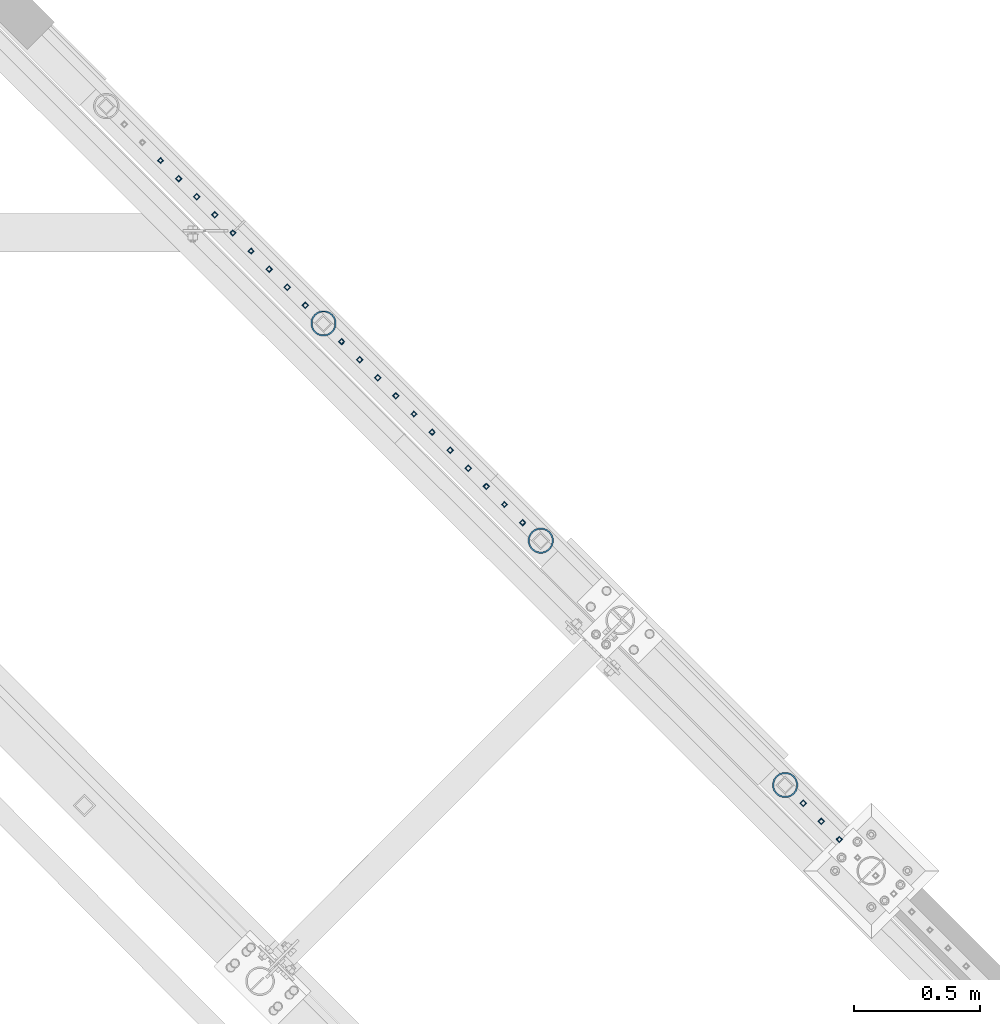
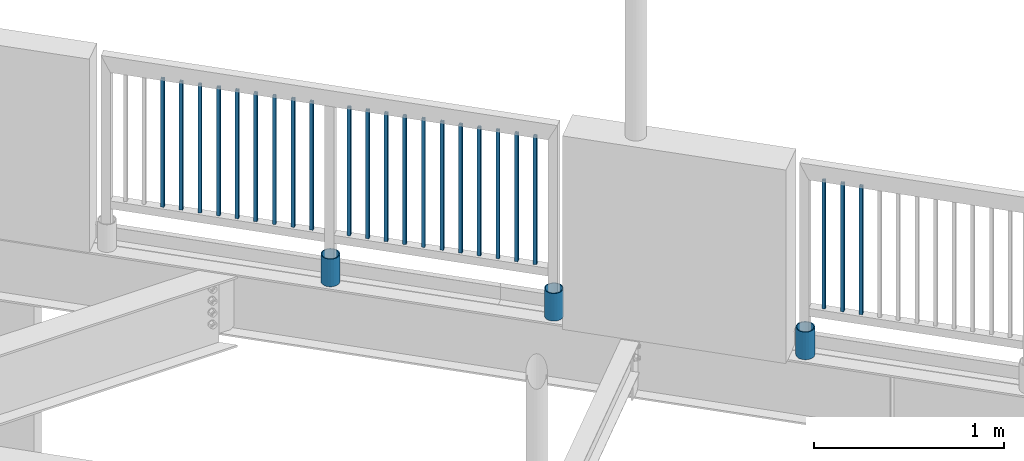
# One storey, part 284 of 975: 26 columns.
"""IFC2X3 building model written with IfcOpenShell, lengths in millimetres."""

from ifc_helpers import new_model, si_unit, frame, origin_with_axes, place, context, subcontext, project, spatial, faceted_brep, material, type_object, element, save


model = new_model("IFC2X3")

# Units and contexts
model_context = context("Model", 3, precision=1e-05, world=origin_with_axes())
body_context = subcontext(model_context, "Body", "Model", "MODEL_VIEW")
ifc_project = project(units=[si_unit("LENGTHUNIT", "METRE", prefix="MILLI"), si_unit("AREAUNIT", "SQUARE_METRE"), si_unit("VOLUMEUNIT", "CUBIC_METRE"), si_unit("MASSUNIT", "GRAM", prefix="KILO"), si_unit("TIMEUNIT", "SECOND"), si_unit("PLANEANGLEUNIT", "RADIAN"), si_unit("SOLIDANGLEUNIT", "STERADIAN"), si_unit("THERMODYNAMICTEMPERATUREUNIT", "DEGREE_CELSIUS"), si_unit("LUMINOUSINTENSITYUNIT", "LUMEN")], contexts=[model_context])

# Site, building, storey
site_placement = place(None, origin_with_axes())
site = spatial("IfcSite", under=ifc_project, at=site_placement, CompositionType="ELEMENT")
building_placement = place(site_placement, origin_with_axes())
building = spatial("IfcBuilding", under=site, at=building_placement, Name="Undefined", CompositionType="ELEMENT")
storey_placement = place(building_placement, origin_with_axes())
storey = spatial("IfcBuildingStorey", under=building, at=storey_placement, Name="Undefined", CompositionType="ELEMENT", Elevation=0.0)

# Columns
ifc_material_1 = material()
column_type_1 = type_object("IfcColumnType", Name="HSS3/4X3/4X.120_TUBES", PredefinedType="NOTDEFINED")
for number, where, z_axis, x_axis, name in (
    (1, (27726.1994759871, 20908.4255492216, 4254.49914984075), (-0.707106781186601, 0.707106781186494, 2.36468622460961e-14), (0.0, 0.0, 1.0), "PICKET"),
    (2, (27798.0338509871, 20836.5911742216, 4254.49914984075), (-0.707106781186601, 0.707106781186494, 2.36468622460961e-14), (0.0, 0.0, 1.0), "PICKET"),
    (3, (27869.8682259871, 20764.7567992216, 4254.49914984075), (-0.707106781186601, 0.707106781186494, 2.36468622460961e-14), (0.0, 0.0, 1.0), "PICKET"),
    (4, (27941.7026009871, 20692.9224242216, 4254.49914984075), (-0.707106781186601, 0.707106781186494, 2.36468622460961e-14), (0.0, 0.0, 1.0), "PICKET"),
    (5, (28013.5369759871, 20621.0880492216, 4254.49914984075), (-0.707106781186601, 0.707106781186494, 2.36468622460961e-14), (0.0, 0.0, 1.0), "PICKET"),
    (6, (28085.3713509871, 20549.2536742216, 4254.49914984075), (-0.707106781186601, 0.707106781186494, 2.36468622460961e-14), (0.0, 0.0, 1.0), "PICKET"),
    (7, (28157.2057259871, 20477.4192992216, 4254.49914984075), (-0.707106781186601, 0.707106781186494, 2.36468622460961e-14), (0.0, 0.0, 1.0), "PICKET"),
    (8, (28229.0401009871, 20405.5849242216, 4254.49914984075), (-0.707106781186601, 0.707106781186494, 2.36468622460961e-14), (0.0, 0.0, 1.0), "PICKET"),
    (9, (28300.8744759871, 20333.7505492216, 4254.49914984075), (-0.707106781186601, 0.707106781186494, 2.36468622460961e-14), (0.0, 0.0, 1.0), "PICKET"),
    (10, (28444.5970604277, 20189.9439310617, 4254.49994796676), (-0.707106781186601, 0.707106781186494, 2.36468622460961e-14), (0.0, 0.0, 1.0), "PICKET"),
    (11, (28516.4314354277, 20118.1095560617, 4254.49994796676), (-0.707106781186601, 0.707106781186494, 2.36468622460961e-14), (0.0, 0.0, 1.0), "PICKET"),
    (12, (28588.2658104277, 20046.2751810617, 4254.49994796676), (-0.707106781186601, 0.707106781186494, 2.36468622460961e-14), (0.0, 0.0, 1.0), "PICKET"),
    (13, (28660.1001854277, 19974.4408060617, 4254.49994796676), (-0.707106781186601, 0.707106781186494, 2.36468622460961e-14), (0.0, 0.0, 1.0), "PICKET"),
    (14, (28731.9345604277, 19902.6064310617, 4254.49994796676), (-0.707106781186601, 0.707106781186494, 2.36468622460961e-14), (0.0, 0.0, 1.0), "PICKET"),
    (15, (28803.7689354277, 19830.7720560617, 4254.49994796676), (-0.707106781186601, 0.707106781186494, 2.36468622460961e-14), (0.0, 0.0, 1.0), "PICKET"),
    (16, (28875.6033104277, 19758.9376810617, 4254.49994796676), (-0.707106781186601, 0.707106781186494, 2.36468622460961e-14), (0.0, 0.0, 1.0), "PICKET"),
    (17, (28947.4376854277, 19687.1033060617, 4254.49994796676), (-0.707106781186601, 0.707106781186494, 2.36468622460961e-14), (0.0, 0.0, 1.0), "PICKET"),
    (18, (29019.2720604277, 19615.2689310617, 4254.49994796676), (-0.707106781186601, 0.707106781186494, 2.36468622460961e-14), (0.0, 0.0, 1.0), "PICKET"),
    (19, (29091.1064354277, 19543.4345560617, 4254.49994796676), (-0.707106781186601, 0.707106781186494, 2.36468622460961e-14), (0.0, 0.0, 1.0), "PICKET"),
    (20, (29162.9408104277, 19471.6001810617, 4254.49994796676), (-0.707106781186601, 0.707106781186494, 2.36468622460961e-14), (0.0, 0.0, 1.0), "PICKET"),
    (21, (30276.5088978262, 18357.923543701, 4254.499875366), (-0.707106781186601, 0.707106781186494, 2.36468622460961e-14), (0.0, 0.0, 1.0), "PICKET"),
    (22, (30348.3432728262, 18286.089168701, 4254.499875366), (-0.707106781186601, 0.707106781186494, 2.36468622460961e-14), (0.0, 0.0, 1.0), "PICKET"),
    (23, (30420.1776478262, 18214.254793701, 4254.499875366), (-0.707106781186601, 0.707106781186494, 2.36468622460961e-14), (0.0, 0.0, 1.0), "PICKET"),
):
    element("IfcColumn", number, at=place(storey_placement, frame(where, z_axis=z_axis, x_axis=x_axis)), inside=storey, type_object=column_type_1, material=ifc_material_1, Name=name, ObjectType="HSS3/4X3/4X.120_TUBES", context=body_context, shape_type="Brep", body=[
        faceted_brep([(0.0, 6.34999999998763, -6.34999999998763), (0.0, -6.35000000000582, -6.34999999998763), (825.49997943247, -6.35000000000582, -6.34999999998763), (825.49997943247, 6.34999999998763, -6.34999999998763), (0.0, -6.34999999998763, 6.34999999998763), (825.49997943247, -6.34999999998763, 6.34999999998763), (0.0, 6.35000000000946, 6.34999999998763), (825.49997943247, 6.35000000000946, 6.34999999998763), (0.0, 9.52499999997963, -9.52499999997963), (0.0, 9.52500000000873, 9.5249999999869), (825.49997943247, 9.52500000000873, 9.5249999999869), (825.49997943247, 9.52499999997963, -9.52499999997963), (0.0, -9.52499999997963, 9.52499999998327), (825.49997943247, -9.52499999997963, 9.52499999998327), (0.0, -9.52500000000873, -9.5249999999869), (825.49997943247, -9.52500000000873, -9.5249999999869)], [[[0, 1, 2, 3]], [[1, 4, 5, 2]], [[4, 6, 7, 5]], [[6, 0, 3, 7]], [[8, 9, 10, 11]], [[9, 12, 13, 10]], [[12, 14, 15, 13]], [[14, 8, 11, 15]], [[13, 15, 11, 10], [5, 7, 3, 2]], [[14, 12, 9, 8], [6, 4, 1, 0]]]),
    ])
ifc_material_2 = material(Name="STEEL/A53")
column_type_2 = type_object("IfcColumnType", Name="PIPE3-1/2STD", PredefinedType="NOTDEFINED")
column_1_placement = place(storey_placement, frame((28372.9128479252, 20262.0233521609, 3937.0), z_axis=(-0.707106781186601, 0.707106781186494, 2.36468622460961e-14), x_axis=(0.0, 0.0, 1.0)))
element("IfcColumn", 24, at=column_1_placement, inside=storey, type_object=column_type_2, material=ifc_material_2, ObjectType="PIPE3-1/2STD", context=body_context, shape_type="Brep", body=[
    faceted_brep([(0.0, -45.0595999999932, 1.45519152283669e-11), (0.0, -42.8542262016344, 13.924182159768), (177.8, -42.8542262016344, 13.924182159768), (177.8, -45.0595999999932, 1.45519152283669e-11), (0.0, -36.45398215971, 26.4853683542424), (177.8, -36.45398215971, 26.4853683542424), (0.0, -26.4853683541623, 36.45398215979), (177.8, -26.4853683541623, 36.45398215979), (0.0, -13.9241821596988, 42.8542262017108), (177.8, -13.9241821596988, 42.8542262017108), (0.0, 3.63797880709171e-11, 45.0596000000514), (177.8, 3.63797880709171e-11, 45.0596000000514), (0.0, 13.9241821597716, 42.8542262017036), (177.8, 13.9241821597716, 42.8542262017036), (0.0, 26.4853683542242, 36.4539821597718), (177.8, 26.4853683542242, 36.4539821597718), (0.0, 36.4539821597537, 26.4853683542206), (177.8, 36.4539821597537, 26.4853683542206), (0.0, 42.8542262016563, 13.9241821597425), (177.8, 42.8542262016563, 13.9241821597425), (0.0, 45.0595999999932, -1.09139364212751e-11), (177.8, 45.0595999999932, -1.09139364212751e-11), (0.0, 42.8542262016344, -13.9241821597643), (177.8, 42.8542262016344, -13.9241821597643), (0.0, 36.45398215971, -26.4853683542387), (177.8, 36.45398215971, -26.4853683542387), (0.0, 26.4853683541623, -36.4539821597864), (177.8, 26.4853683541623, -36.4539821597864), (0.0, 13.9241821596988, -42.8542262017072), (177.8, 13.9241821596988, -42.8542262017072), (0.0, -3.63797880709171e-11, -45.0596000000478), (177.8, -3.63797880709171e-11, -45.0596000000478), (0.0, -13.9241821597716, -42.8542262016963), (177.8, -13.9241821597716, -42.8542262016963), (0.0, -26.4853683542242, -36.4539821597682), (177.8, -26.4853683542242, -36.4539821597682), (0.0, -36.4539821597537, -26.4853683542169), (177.8, -36.4539821597537, -26.4853683542169), (0.0, -42.8542262016563, -13.9241821597352), (177.8, -42.8542262016563, -13.9241821597352), (0.0, -50.799999999992, 1.81898940354586e-11), (0.0, -48.3136710278013, -15.6980633142484), (177.8, -48.3136710278013, -15.6980633142484), (177.8, -50.799999999992, 1.81898940354586e-11), (0.0, -41.0980633142644, -29.8594908164741), (177.8, -41.0980633142644, -29.8594908164741), (0.0, -29.859490816485, -41.0980633142826), (177.8, -29.859490816485, -41.0980633142826), (0.0, -15.6980633142848, -48.313671027845), (177.8, -15.6980633142848, -48.313671027845), (0.0, -4.36557456851006e-11, -50.8000000000575), (177.8, -4.36557456851006e-11, -50.8000000000575), (0.0, 15.6980633142011, -48.3136710278523), (177.8, 15.6980633142011, -48.3136710278523), (0.0, 29.8594908164159, -41.0980633143045), (177.8, 29.8594908164159, -41.0980633143045), (0.0, 41.0980633142135, -29.8594908165032), (177.8, 41.0980633142135, -29.8594908165032), (0.0, 48.3136710277722, -15.6980633142775), (177.8, 48.3136710277722, -15.6980633142775), (0.0, 50.799999999992, -1.45519152283669e-11), (177.8, 50.799999999992, -1.45519152283669e-11), (0.0, 48.313671027794, 15.6980633142521), (177.8, 48.313671027794, 15.6980633142521), (0.0, 41.0980633142644, 29.8594908164814), (177.8, 41.0980633142644, 29.8594908164814), (0.0, 29.859490816485, 41.0980633142863), (177.8, 29.859490816485, 41.0980633142863), (0.0, 15.6980633142848, 48.3136710278486), (177.8, 15.6980633142848, 48.3136710278486), (0.0, 4.00177668780088e-11, 50.8000000000611), (177.8, 4.00177668780088e-11, 50.8000000000611), (0.0, -15.6980633142011, 48.3136710278559), (177.8, -15.6980633142011, 48.3136710278559), (0.0, -29.8594908164159, 41.0980633143081), (177.8, -29.8594908164159, 41.0980633143081), (0.0, -41.0980633142171, 29.8594908165069), (177.8, -41.0980633142171, 29.8594908165069), (0.0, -48.3136710277722, 15.6980633142812), (177.8, -48.3136710277722, 15.6980633142812)], [[[0, 1, 2, 3]], [[1, 4, 5, 2]], [[4, 6, 7, 5]], [[6, 8, 9, 7]], [[8, 10, 11, 9]], [[10, 12, 13, 11]], [[12, 14, 15, 13]], [[14, 16, 17, 15]], [[16, 18, 19, 17]], [[18, 20, 21, 19]], [[20, 22, 23, 21]], [[22, 24, 25, 23]], [[24, 26, 27, 25]], [[26, 28, 29, 27]], [[28, 30, 31, 29]], [[30, 32, 33, 31]], [[32, 34, 35, 33]], [[34, 36, 37, 35]], [[36, 38, 39, 37]], [[38, 0, 3, 39]], [[40, 41, 42, 43]], [[41, 44, 45, 42]], [[44, 46, 47, 45]], [[46, 48, 49, 47]], [[48, 50, 51, 49]], [[50, 52, 53, 51]], [[52, 54, 55, 53]], [[54, 56, 57, 55]], [[56, 58, 59, 57]], [[58, 60, 61, 59]], [[60, 62, 63, 61]], [[62, 64, 65, 63]], [[64, 66, 67, 65]], [[66, 68, 69, 67]], [[68, 70, 71, 69]], [[70, 72, 73, 71]], [[72, 74, 75, 73]], [[74, 76, 77, 75]], [[76, 78, 79, 77]], [[78, 40, 43, 79]], [[45, 47, 49, 51, 53, 55, 57, 59, 61, 63, 65, 67, 69, 71, 73, 75, 77, 79, 43, 42], [5, 7, 9, 11, 13, 15, 17, 19, 21, 23, 25, 27, 29, 31, 33, 35, 37, 39, 3, 2]], [[78, 76, 74, 72, 70, 68, 66, 64, 62, 60, 58, 56, 54, 52, 50, 48, 46, 44, 41, 40], [38, 36, 34, 32, 30, 28, 26, 24, 22, 20, 18, 16, 14, 12, 10, 8, 6, 4, 1, 0]]]),
])
column_2_placement = place(storey_placement, frame((29235.1198343983, 19400.1776679328, 3937.0), z_axis=(-0.707106781186601, 0.707106781186494, 2.36468622460961e-14), x_axis=(0.0, 0.0, 1.0)))
element("IfcColumn", 25, at=column_2_placement, inside=storey, type_object=column_type_2, material=ifc_material_2, ObjectType="PIPE3-1/2STD", context=body_context, shape_type="Brep", body=[
    faceted_brep([(0.0, -45.0595999999932, 1.45519152283669e-11), (0.0, -42.8542262016344, 13.924182159768), (177.8, -42.8542262016344, 13.924182159768), (177.8, -45.0595999999932, 1.45519152283669e-11), (0.0, -36.45398215971, 26.4853683542424), (177.8, -36.45398215971, 26.4853683542424), (0.0, -26.4853683541623, 36.45398215979), (177.8, -26.4853683541623, 36.45398215979), (0.0, -13.9241821596988, 42.8542262017108), (177.8, -13.9241821596988, 42.8542262017108), (0.0, 3.63797880709171e-11, 45.0596000000514), (177.8, 3.63797880709171e-11, 45.0596000000514), (0.0, 13.9241821597716, 42.8542262017036), (177.8, 13.9241821597716, 42.8542262017036), (0.0, 26.4853683542242, 36.4539821597718), (177.8, 26.4853683542242, 36.4539821597718), (0.0, 36.4539821597537, 26.4853683542206), (177.8, 36.4539821597537, 26.4853683542206), (0.0, 42.8542262016563, 13.9241821597425), (177.8, 42.8542262016563, 13.9241821597425), (0.0, 45.0595999999932, -1.09139364212751e-11), (177.8, 45.0595999999932, -1.09139364212751e-11), (0.0, 42.8542262016344, -13.9241821597643), (177.8, 42.8542262016344, -13.9241821597643), (0.0, 36.45398215971, -26.4853683542387), (177.8, 36.45398215971, -26.4853683542387), (0.0, 26.4853683541623, -36.4539821597864), (177.8, 26.4853683541623, -36.4539821597864), (0.0, 13.9241821596988, -42.8542262017072), (177.8, 13.9241821596988, -42.8542262017072), (0.0, -3.63797880709171e-11, -45.0596000000478), (177.8, -3.63797880709171e-11, -45.0596000000478), (0.0, -13.9241821597716, -42.8542262016963), (177.8, -13.9241821597716, -42.8542262016963), (0.0, -26.4853683542242, -36.4539821597682), (177.8, -26.4853683542242, -36.4539821597682), (0.0, -36.4539821597537, -26.4853683542169), (177.8, -36.4539821597537, -26.4853683542169), (0.0, -42.8542262016563, -13.9241821597352), (177.8, -42.8542262016563, -13.9241821597352), (0.0, -50.799999999992, 1.81898940354586e-11), (0.0, -48.3136710278013, -15.6980633142484), (177.8, -48.3136710278013, -15.6980633142484), (177.8, -50.799999999992, 1.81898940354586e-11), (0.0, -41.0980633142644, -29.8594908164741), (177.8, -41.0980633142644, -29.8594908164741), (0.0, -29.859490816485, -41.0980633142826), (177.8, -29.859490816485, -41.0980633142826), (0.0, -15.6980633142848, -48.313671027845), (177.8, -15.6980633142848, -48.313671027845), (0.0, -4.36557456851006e-11, -50.8000000000575), (177.8, -4.36557456851006e-11, -50.8000000000575), (0.0, 15.6980633142011, -48.3136710278523), (177.8, 15.6980633142011, -48.3136710278523), (0.0, 29.8594908164159, -41.0980633143045), (177.8, 29.8594908164159, -41.0980633143045), (0.0, 41.0980633142135, -29.8594908165032), (177.8, 41.0980633142135, -29.8594908165032), (0.0, 48.3136710277722, -15.6980633142775), (177.8, 48.3136710277722, -15.6980633142775), (0.0, 50.799999999992, -1.45519152283669e-11), (177.8, 50.799999999992, -1.45519152283669e-11), (0.0, 48.313671027794, 15.6980633142521), (177.8, 48.313671027794, 15.6980633142521), (0.0, 41.0980633142644, 29.8594908164814), (177.8, 41.0980633142644, 29.8594908164814), (0.0, 29.859490816485, 41.0980633142863), (177.8, 29.859490816485, 41.0980633142863), (0.0, 15.6980633142848, 48.3136710278486), (177.8, 15.6980633142848, 48.3136710278486), (0.0, 4.00177668780088e-11, 50.8000000000611), (177.8, 4.00177668780088e-11, 50.8000000000611), (0.0, -15.6980633142011, 48.3136710278559), (177.8, -15.6980633142011, 48.3136710278559), (0.0, -29.8594908164159, 41.0980633143081), (177.8, -29.8594908164159, 41.0980633143081), (0.0, -41.0980633142171, 29.8594908165069), (177.8, -41.0980633142171, 29.8594908165069), (0.0, -48.3136710277722, 15.6980633142812), (177.8, -48.3136710277722, 15.6980633142812)], [[[0, 1, 2, 3]], [[1, 4, 5, 2]], [[4, 6, 7, 5]], [[6, 8, 9, 7]], [[8, 10, 11, 9]], [[10, 12, 13, 11]], [[12, 14, 15, 13]], [[14, 16, 17, 15]], [[16, 18, 19, 17]], [[18, 20, 21, 19]], [[20, 22, 23, 21]], [[22, 24, 25, 23]], [[24, 26, 27, 25]], [[26, 28, 29, 27]], [[28, 30, 31, 29]], [[30, 32, 33, 31]], [[32, 34, 35, 33]], [[34, 36, 37, 35]], [[36, 38, 39, 37]], [[38, 0, 3, 39]], [[40, 41, 42, 43]], [[41, 44, 45, 42]], [[44, 46, 47, 45]], [[46, 48, 49, 47]], [[48, 50, 51, 49]], [[50, 52, 53, 51]], [[52, 54, 55, 53]], [[54, 56, 57, 55]], [[56, 58, 59, 57]], [[58, 60, 61, 59]], [[60, 62, 63, 61]], [[62, 64, 65, 63]], [[64, 66, 67, 65]], [[66, 68, 69, 67]], [[68, 70, 71, 69]], [[70, 72, 73, 71]], [[72, 74, 75, 73]], [[74, 76, 77, 75]], [[76, 78, 79, 77]], [[78, 40, 43, 79]], [[45, 47, 49, 51, 53, 55, 57, 59, 61, 63, 65, 67, 69, 71, 73, 75, 77, 79, 43, 42], [5, 7, 9, 11, 13, 15, 17, 19, 21, 23, 25, 27, 29, 31, 33, 35, 37, 39, 3, 2]], [[78, 76, 74, 72, 70, 68, 66, 64, 62, 60, 58, 56, 54, 52, 50, 48, 46, 44, 41, 40], [38, 36, 34, 32, 30, 28, 26, 24, 22, 20, 18, 16, 14, 12, 10, 8, 6, 4, 1, 0]]]),
])
column_3_placement = place(storey_placement, frame((30204.902387649, 18430.2447051545, 3937.0), z_axis=(-0.707106781186601, 0.707106781186494, 2.36468622460961e-14), x_axis=(0.0, 0.0, 1.0)))
element("IfcColumn", 26, at=column_3_placement, inside=storey, type_object=column_type_2, material=ifc_material_2, ObjectType="PIPE3-1/2STD", context=body_context, shape_type="Brep", body=[
    faceted_brep([(0.0, -45.0595999999932, 1.45519152283669e-11), (0.0, -42.8542262016344, 13.924182159768), (177.8, -42.8542262016344, 13.924182159768), (177.8, -45.0595999999932, 1.45519152283669e-11), (0.0, -36.45398215971, 26.4853683542424), (177.8, -36.45398215971, 26.4853683542424), (0.0, -26.4853683541623, 36.45398215979), (177.8, -26.4853683541623, 36.45398215979), (0.0, -13.9241821596988, 42.8542262017108), (177.8, -13.9241821596988, 42.8542262017108), (0.0, 3.63797880709171e-11, 45.0596000000514), (177.8, 3.63797880709171e-11, 45.0596000000514), (0.0, 13.9241821597716, 42.8542262017036), (177.8, 13.9241821597716, 42.8542262017036), (0.0, 26.4853683542242, 36.4539821597718), (177.8, 26.4853683542242, 36.4539821597718), (0.0, 36.4539821597537, 26.4853683542206), (177.8, 36.4539821597537, 26.4853683542206), (0.0, 42.8542262016563, 13.9241821597425), (177.8, 42.8542262016563, 13.9241821597425), (0.0, 45.0595999999932, -1.09139364212751e-11), (177.8, 45.0595999999932, -1.09139364212751e-11), (0.0, 42.8542262016344, -13.9241821597643), (177.8, 42.8542262016344, -13.9241821597643), (0.0, 36.45398215971, -26.4853683542387), (177.8, 36.45398215971, -26.4853683542387), (0.0, 26.4853683541623, -36.4539821597864), (177.8, 26.4853683541623, -36.4539821597864), (0.0, 13.9241821596988, -42.8542262017072), (177.8, 13.9241821596988, -42.8542262017072), (0.0, -3.63797880709171e-11, -45.0596000000478), (177.8, -3.63797880709171e-11, -45.0596000000478), (0.0, -13.9241821597716, -42.8542262016963), (177.8, -13.9241821597716, -42.8542262016963), (0.0, -26.4853683542242, -36.4539821597682), (177.8, -26.4853683542242, -36.4539821597682), (0.0, -36.4539821597537, -26.4853683542169), (177.8, -36.4539821597537, -26.4853683542169), (0.0, -42.8542262016563, -13.9241821597352), (177.8, -42.8542262016563, -13.9241821597352), (0.0, -50.799999999992, 1.81898940354586e-11), (0.0, -48.3136710278013, -15.6980633142484), (177.8, -48.3136710278013, -15.6980633142484), (177.8, -50.799999999992, 1.81898940354586e-11), (0.0, -41.0980633142644, -29.8594908164741), (177.8, -41.0980633142644, -29.8594908164741), (0.0, -29.859490816485, -41.0980633142826), (177.8, -29.859490816485, -41.0980633142826), (0.0, -15.6980633142848, -48.313671027845), (177.8, -15.6980633142848, -48.313671027845), (0.0, -4.36557456851006e-11, -50.8000000000575), (177.8, -4.36557456851006e-11, -50.8000000000575), (0.0, 15.6980633142011, -48.3136710278523), (177.8, 15.6980633142011, -48.3136710278523), (0.0, 29.8594908164159, -41.0980633143045), (177.8, 29.8594908164159, -41.0980633143045), (0.0, 41.0980633142135, -29.8594908165032), (177.8, 41.0980633142135, -29.8594908165032), (0.0, 48.3136710277722, -15.6980633142775), (177.8, 48.3136710277722, -15.6980633142775), (0.0, 50.799999999992, -1.45519152283669e-11), (177.8, 50.799999999992, -1.45519152283669e-11), (0.0, 48.313671027794, 15.6980633142521), (177.8, 48.313671027794, 15.6980633142521), (0.0, 41.0980633142644, 29.8594908164814), (177.8, 41.0980633142644, 29.8594908164814), (0.0, 29.859490816485, 41.0980633142863), (177.8, 29.859490816485, 41.0980633142863), (0.0, 15.6980633142848, 48.3136710278486), (177.8, 15.6980633142848, 48.3136710278486), (0.0, 4.00177668780088e-11, 50.8000000000611), (177.8, 4.00177668780088e-11, 50.8000000000611), (0.0, -15.6980633142011, 48.3136710278559), (177.8, -15.6980633142011, 48.3136710278559), (0.0, -29.8594908164159, 41.0980633143081), (177.8, -29.8594908164159, 41.0980633143081), (0.0, -41.0980633142171, 29.8594908165069), (177.8, -41.0980633142171, 29.8594908165069), (0.0, -48.3136710277722, 15.6980633142812), (177.8, -48.3136710277722, 15.6980633142812)], [[[0, 1, 2, 3]], [[1, 4, 5, 2]], [[4, 6, 7, 5]], [[6, 8, 9, 7]], [[8, 10, 11, 9]], [[10, 12, 13, 11]], [[12, 14, 15, 13]], [[14, 16, 17, 15]], [[16, 18, 19, 17]], [[18, 20, 21, 19]], [[20, 22, 23, 21]], [[22, 24, 25, 23]], [[24, 26, 27, 25]], [[26, 28, 29, 27]], [[28, 30, 31, 29]], [[30, 32, 33, 31]], [[32, 34, 35, 33]], [[34, 36, 37, 35]], [[36, 38, 39, 37]], [[38, 0, 3, 39]], [[40, 41, 42, 43]], [[41, 44, 45, 42]], [[44, 46, 47, 45]], [[46, 48, 49, 47]], [[48, 50, 51, 49]], [[50, 52, 53, 51]], [[52, 54, 55, 53]], [[54, 56, 57, 55]], [[56, 58, 59, 57]], [[58, 60, 61, 59]], [[60, 62, 63, 61]], [[62, 64, 65, 63]], [[64, 66, 67, 65]], [[66, 68, 69, 67]], [[68, 70, 71, 69]], [[70, 72, 73, 71]], [[72, 74, 75, 73]], [[74, 76, 77, 75]], [[76, 78, 79, 77]], [[78, 40, 43, 79]], [[45, 47, 49, 51, 53, 55, 57, 59, 61, 63, 65, 67, 69, 71, 73, 75, 77, 79, 43, 42], [5, 7, 9, 11, 13, 15, 17, 19, 21, 23, 25, 27, 29, 31, 33, 35, 37, 39, 3, 2]], [[78, 76, 74, 72, 70, 68, 66, 64, 62, 60, 58, 56, 54, 52, 50, 48, 46, 44, 41, 40], [38, 36, 34, 32, 30, 28, 26, 24, 22, 20, 18, 16, 14, 12, 10, 8, 6, 4, 1, 0]]]),
])

save(model, "model.ifc")
